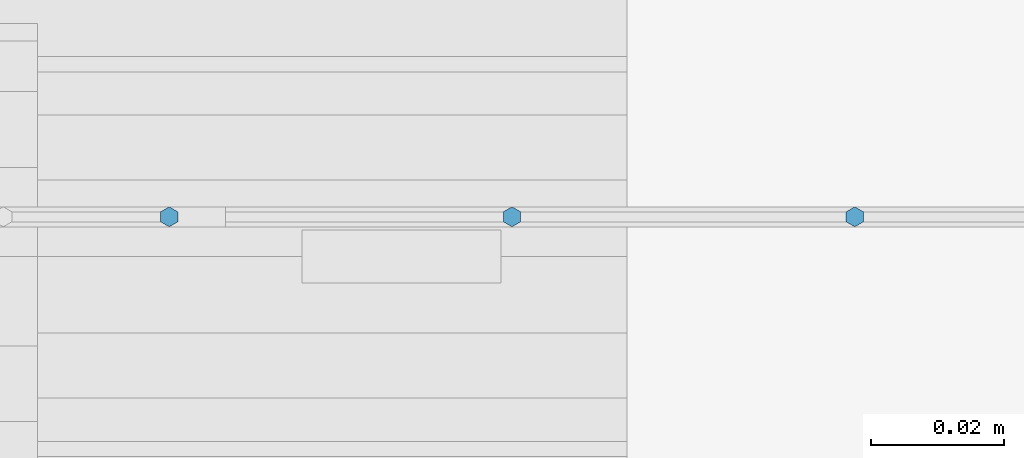
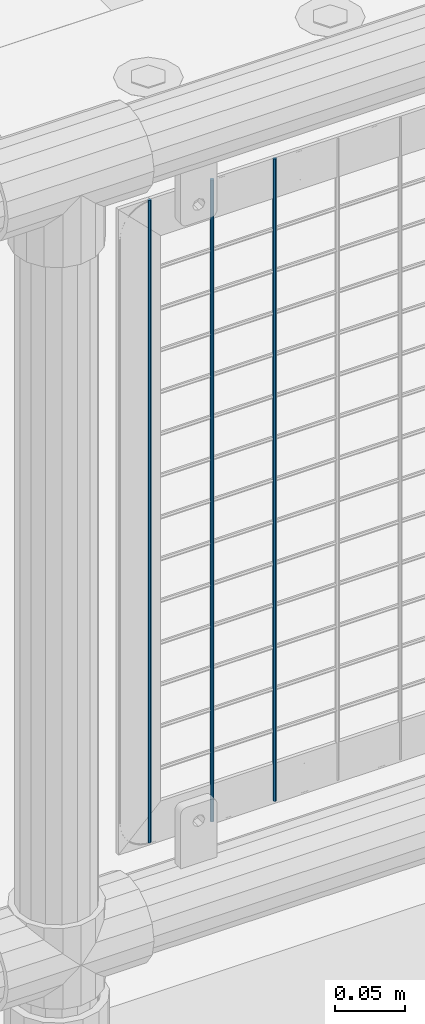
# One storey, part 89 of 240: 3 columns.
"""IFC2X3 building model written with IfcOpenShell, lengths in millimetres."""

from ifc_helpers import new_model, si_unit, frame, origin_with_axes, place, context, subcontext, project, spatial, faceted_brep, material, type_object, element, save


model = new_model("IFC2X3")

# Units and contexts
model_context = context("Model", 3, precision=1e-05, world=origin_with_axes())
body_context = subcontext(model_context, "Body", "Model", "MODEL_VIEW")
ifc_project = project(units=[si_unit("LENGTHUNIT", "METRE", prefix="MILLI"), si_unit("AREAUNIT", "SQUARE_METRE"), si_unit("VOLUMEUNIT", "CUBIC_METRE"), si_unit("MASSUNIT", "GRAM", prefix="KILO"), si_unit("TIMEUNIT", "SECOND"), si_unit("PLANEANGLEUNIT", "RADIAN"), si_unit("SOLIDANGLEUNIT", "STERADIAN"), si_unit("THERMODYNAMICTEMPERATUREUNIT", "DEGREE_CELSIUS"), si_unit("LUMINOUSINTENSITYUNIT", "LUMEN")], contexts=[model_context])

# Site, building, storey
site_placement = place(None, origin_with_axes())
site = spatial("IfcSite", under=ifc_project, at=site_placement, CompositionType="ELEMENT")
building_placement = place(site_placement, origin_with_axes())
building = spatial("IfcBuilding", under=site, at=building_placement, Name="Standard", CompositionType="ELEMENT")
storey_placement = place(building_placement, origin_with_axes())
storey = spatial("IfcBuildingStorey", under=building, at=storey_placement, Name="Undefined", CompositionType="ELEMENT", Elevation=0.0)

# Columns
ifc_material = material(Name="Misc_Undefined")
column_type = type_object("IfcColumnType", Name="D3", PredefinedType="NOTDEFINED")
for number, where, z_axis, x_axis in (
    (1, (51544.31, 34670.5, 353.020000000001), (-1.0, 0.0, 0.0), (0.0, 0.0, 1.0)),
    (2, (51492.655, 34670.5, 353.020000000001), (-1.0, 0.0, 0.0), (0.0, 0.0, 1.0)),
    (3, (51441.0, 34670.5, 353.020000000001), (-1.0, 0.0, 0.0), (0.0, 0.0, 1.0)),
):
    element("IfcColumn", number, at=place(storey_placement, frame(where, z_axis=z_axis, x_axis=x_axis)), inside=storey, type_object=column_type, material=ifc_material, ObjectType="D3", context=body_context, shape_type="Brep", body=[
        faceted_brep([(-7.27595761418343e-12, -1.49999999999272, 0.0), (-7.27595761418343e-12, -0.749999999992724, -1.29903810567669), (560.0, -0.75, -1.29903810567339), (560.0, -1.5, 0.0), (0.0, 0.750000000007276, -1.29903810567669), (560.0, 0.75, -1.29903810567339), (0.0, 1.50000000000728, 0.0), (560.0, 1.5, 0.0), (0.0, 0.750000000007276, 1.29903810567669), (560.0, 0.75, 1.29903810567339), (-7.27595761418343e-12, -0.749999999992724, 1.29903810567669), (560.0, -0.75, 1.29903810567339)], [[[0, 1, 2, 3]], [[1, 4, 5, 2]], [[4, 6, 7, 5]], [[6, 8, 9, 7]], [[8, 10, 11, 9]], [[10, 0, 3, 11]], [[5, 7, 9, 11, 3, 2]], [[10, 8, 6, 4, 1, 0]]]),
    ])

save(model, "model.ifc")
